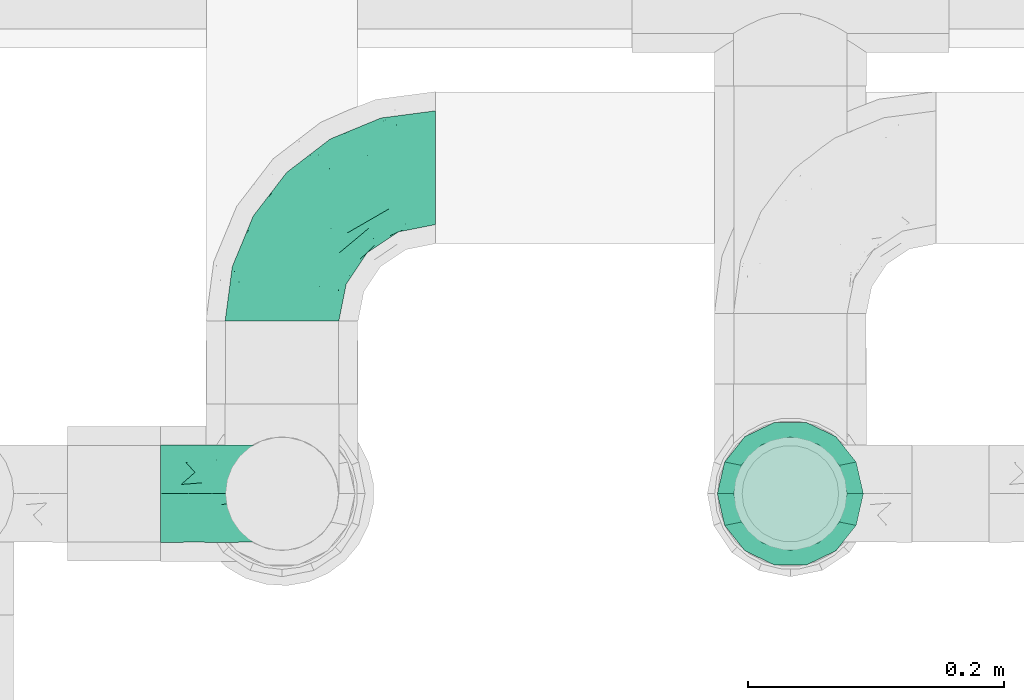
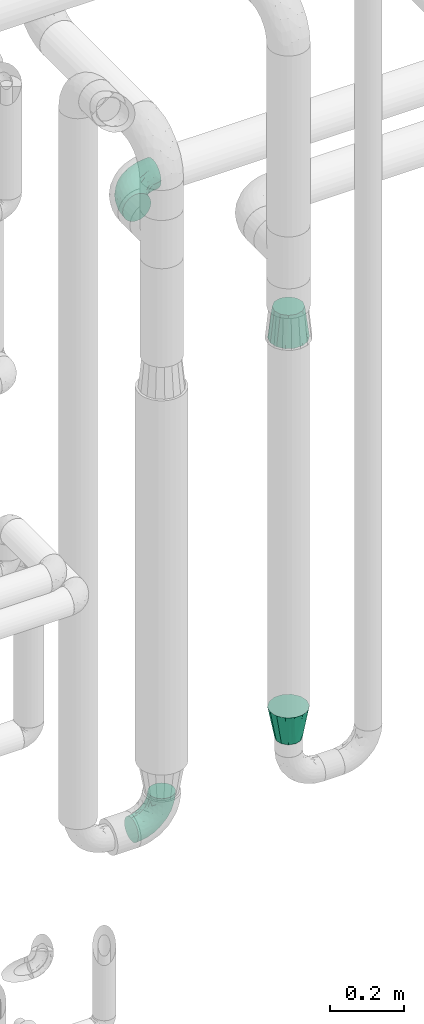
# One storey, part 708 of 827: 4 flow fittings.
"""IFC2X3 building model written with IfcOpenShell, lengths in millimetres."""

import ifcopenshell
import ifcopenshell.guid

model = None  # the IFC model being written
_history = None  # IfcOwnerHistory: only IFC2X3 demands one
_inside = {}  # id of a spatial element -> (the spatial element, [elements in it])
_under = {}  # id of a project, library or spatial element -> (it, [spatial elements below it])
_declared = {}  # id of a project -> (the project, [libraries it declares])
_typed = {}  # id of a type object -> (the type object, [elements of that type])
_made_of = {}  # id of a material, layer set ... -> (it, [elements and type objects made of it])


def new_model(schema):
    """Start an empty IFC model of exactly this schema.

    Asked for "IFC4X3", IfcOpenShell would pick the latest addendum, in which some entities
    have other attributes; the version numbers below select the first issue.
    IFC2X3 requires an IfcOwnerHistory on every rooted entity: one is made here for all.
    """
    global model, _history
    if schema == "IFC4X3":
        model = ifcopenshell.file(schema_version=(4, 3, 0, 0))
    else:
        model = ifcopenshell.file(schema=schema)
    _inside.clear()
    _under.clear()
    _declared.clear()
    _typed.clear()
    _made_of.clear()
    _history = None
    if model.schema == "IFC2X3":
        org = make("IfcOrganization", Name="unknown")
        user = make(
            "IfcPersonAndOrganization",
            ThePerson=make("IfcPerson", FamilyName="unknown"),
            TheOrganization=org,
        )
        app = make(
            "IfcApplication",
            ApplicationDeveloper=org,
            Version="unknown",
            ApplicationFullName="unknown",
            ApplicationIdentifier="unknown",
        )
        _history = make(
            "IfcOwnerHistory",
            OwningUser=user,
            OwningApplication=app,
            ChangeAction="ADDED",
            CreationDate=0,
        )
    return model


def make(cls, **values):
    """One entity of the class cls with the attributes given. An attribute that is None is left unset."""
    return model.create_entity(
        cls, **{name: value for name, value in values.items() if value is not None}
    )


def entity(cls, *values):
    """Any entity or typed value of the class cls, its attributes in the order of the schema. None: left unset."""
    e = model.create_entity(cls)
    for i, value in enumerate(values):
        if value is not None:
            e[i] = value
    return e


def rooted(cls, **values):
    """An entity with a GlobalId (a new one), such as an element, a storey or a relation."""
    return make(cls, GlobalId=ifcopenshell.guid.new(), OwnerHistory=_history, **values)


def si_unit(unit_type, name, prefix=None):
    """IfcSIUnit, for example si_unit("LENGTHUNIT", "METRE", prefix="MILLI")."""
    return make("IfcSIUnit", UnitType=unit_type, Prefix=prefix, Name=name)


def converted_unit(unit_type, name, factor, base, dimensions=None, offset=None):
    """IfcConversionBasedUnit, such as the inch: factor (a typed value) times the base unit."""
    return make(
        "IfcConversionBasedUnit"
        if offset is None
        else "IfcConversionBasedUnitWithOffset",
        ConversionOffset=offset,
        Dimensions=None
        if dimensions is None
        else entity("IfcDimensionalExponents", *dimensions),
        UnitType=unit_type,
        Name=name,
        ConversionFactor=make(
            "IfcMeasureWithUnit", ValueComponent=factor, UnitComponent=base
        ),
    )


def derived_unit(unit_type, elements):
    """IfcDerivedUnit: a product of units, each with its exponent."""
    return make(
        "IfcDerivedUnit",
        Elements=[
            make("IfcDerivedUnitElement", Unit=unit, Exponent=power)
            for unit, power in elements
        ],
        UnitType=unit_type,
    )


def assignment(units):
    """IfcUnitAssignment: the units of a project."""
    return None if units is None else make("IfcUnitAssignment", Units=units)


def point(xyz):
    """IfcCartesianPoint."""
    return None if xyz is None else make("IfcCartesianPoint", Coordinates=xyz)


def direction(xyz):
    """IfcDirection."""
    return None if xyz is None else make("IfcDirection", DirectionRatios=xyz)


def frame(location, z_axis=None, x_axis=None):
    """IfcAxis2Placement3D, a coordinate frame: its origin and axes. An axis left out is left unset."""
    return make(
        "IfcAxis2Placement3D",
        Location=point(location),
        Axis=direction(z_axis),
        RefDirection=direction(x_axis),
    )


def origin():
    """The frame at (0, 0, 0) with its axes left unset."""
    return frame((0.0, 0.0, 0.0))


def place(relative_to, where):
    """IfcLocalPlacement: puts the frame where relative to a parent placement (None: the world)."""
    return make(
        "IfcLocalPlacement", PlacementRelTo=relative_to, RelativePlacement=where
    )


def context(
    kind, dimensions, precision=None, world=None, true_north=None, identifier=None
):
    """IfcGeometricRepresentationContext, for example the 3D "Model" context."""
    return make(
        "IfcGeometricRepresentationContext",
        ContextIdentifier=identifier,
        ContextType=kind,
        CoordinateSpaceDimension=dimensions,
        Precision=precision,
        WorldCoordinateSystem=world,
        TrueNorth=true_north,
    )


def subcontext(parent, identifier, kind, view, scale=None):
    """IfcGeometricRepresentationSubContext, for example "Body" below "Model"."""
    return make(
        "IfcGeometricRepresentationSubContext",
        ContextIdentifier=identifier,
        ContextType=kind,
        ParentContext=parent,
        TargetScale=scale,
        TargetView=view,
    )


def project(units=None, contexts=None):
    """IfcProject with its units and contexts."""
    return rooted(
        "IfcProject",
        Name="project",
        RepresentationContexts=contexts,
        UnitsInContext=assignment(units),
    )


def spatial(cls, under=None, at=None, **own):
    """A site, building, storey or space (cls), placed at a placement, below another one or the project."""
    s = rooted(cls, ObjectPlacement=at, **own)
    if under is not None:
        _under.setdefault(under.id(), (under, []))[1].append(s)
    return s


def faces_of(points, faces, orient=None, outer=None):
    """IfcFace entities. A face is a list of loops; a loop is a list of indices into points, from 0.

    orient and outer hold one flag for each loop. By default every Orientation is true, the
    first loop of a face is its IfcFaceOuterBound and the others are IfcFaceBound.
    """
    made = []
    for i, loops in enumerate(faces):
        bounds = []
        for j, loop in enumerate(loops):
            is_outer = j == 0 if outer is None else outer[i][j]
            bounds.append(
                make(
                    "IfcFaceOuterBound" if is_outer else "IfcFaceBound",
                    Bound=make("IfcPolyLoop", Polygon=[points[k] for k in loop]),
                    Orientation=True if orient is None else orient[i][j],
                )
            )
        made.append(make("IfcFace", Bounds=bounds))
    return made


def faceted_brep(points, faces, orient=None, outer=None, voids=None):
    """IfcFacetedBrep: a solid bounded by flat faces; with voids (closed shells), ...WithVoids."""
    shared = [point(p) for p in points]
    hull = make("IfcClosedShell", CfsFaces=faces_of(shared, faces, orient, outer))
    if voids is None:
        return make("IfcFacetedBrep", Outer=hull)
    return make(
        "IfcFacetedBrepWithVoids",
        Outer=hull,
        Voids=[
            make(cls, CfsFaces=faces_of(shared, fs, o, b)) for cls, fs, o, b in voids
        ],
    )


def shape(context_of_items, identifier, shape_type, items):
    """IfcShapeRepresentation: the items that make up one representation, for example the "Body"."""
    return make(
        "IfcShapeRepresentation",
        ContextOfItems=context_of_items,
        RepresentationIdentifier=identifier,
        RepresentationType=shape_type,
        Items=items,
    )


def source(mapping_origin, context_of_items, identifier, shape_type, items):
    """IfcRepresentationMap: a shape defined once, which mapped items show again and again."""
    return make(
        "IfcRepresentationMap",
        MappingOrigin=mapping_origin,
        MappedRepresentation=shape(context_of_items, identifier, shape_type, items),
    )


def transform(
    local_origin,
    x_axis=None,
    y_axis=None,
    z_axis=None,
    scale=None,
    scale2=None,
    scale3=None,
    uniform=True,
):
    """IfcCartesianTransformationOperator3D, or its non-uniform kind. x_axis, y_axis, z_axis: its Axis1, 2, 3."""
    if uniform:
        return make(
            "IfcCartesianTransformationOperator3D",
            Axis1=direction(x_axis),
            Axis2=direction(y_axis),
            LocalOrigin=point(local_origin),
            Scale=scale,
            Axis3=direction(z_axis),
        )
    return make(
        "IfcCartesianTransformationOperator3DnonUniform",
        Axis1=direction(x_axis),
        Axis2=direction(y_axis),
        LocalOrigin=point(local_origin),
        Scale=scale,
        Axis3=direction(z_axis),
        Scale2=scale2,
        Scale3=scale3,
    )


def mapped(mapping_source, mapping_target):
    """IfcMappedItem: shows the shape of a source again, moved by a transform."""
    return make(
        "IfcMappedItem", MappingSource=mapping_source, MappingTarget=mapping_target
    )


def material(Name=None, Category=None):
    """IfcMaterial."""
    return make("IfcMaterial", Name=Name, Category=Category)


def made_of(thing, what):
    """Note that an element or type object is made of a material, layer set ...; save() writes the relation."""
    if what is not None:
        _made_of.setdefault(what.id(), (what, []))[1].append(thing)
    return thing


def type_object(cls, material=None, **own):
    """A type object (cls), such as IfcWallType, which elements share."""
    return made_of(rooted(cls, **own), material)


def type_shapes(of_type, sources):
    """Give a type object the sources (RepresentationMaps) that its elements show as mapped items."""
    of_type.RepresentationMaps = sources


def element(
    cls,
    number,
    at=None,
    inside=None,
    cuts=None,
    type_object=None,
    material=None,
    context=None,
    identifier="Body",
    shape_type=None,
    held_by="IfcProductDefinitionShape",
    body=None,
    shapes=None,
    **own,
):
    """One element of the class cls, such as IfcWall. Its Tag is "e" and its number.

    at: its placement. inside: the storey or other place that contains it. cuts: it is an
    opening in that element (IfcRelVoidsElement). A single representation is given by context,
    identifier, shape_type and body (its items); several are given by shapes. held_by: the class
    of the entity that holds the representations. save() writes the other relations.
    """
    e = rooted(cls, Tag="e%d" % number, ObjectPlacement=at, **own)
    if body is not None:
        shapes = [shape(context, identifier, shape_type, body)]
    if shapes is not None:
        e.Representation = make(held_by, Representations=shapes)
    if inside is not None:
        _inside.setdefault(inside.id(), (inside, []))[1].append(e)
    if cuts is not None:
        rooted(
            "IfcRelVoidsElement", RelatingBuildingElement=cuts, RelatedOpeningElement=e
        )
    if type_object is not None:
        _typed.setdefault(type_object.id(), (type_object, []))[1].append(e)
    return made_of(e, material)


def aggregate(whole, parts):
    """IfcRelAggregates: a whole, such as a stair, and the parts it consists of."""
    return rooted("IfcRelAggregates", RelatingObject=whole, RelatedObjects=parts)


def save(model, path):
    """Write the relations noted so far, then the file.

    IfcRelAggregates (storeys below a building ...), IfcRelContainedInSpatialStructure (elements
    in a storey), IfcRelDefinesByType, IfcRelAssociatesMaterial and IfcRelDeclares: one each for
    every whole, place, type object, material and project.
    """
    for whole, parts in _under.values():
        aggregate(whole, parts)
    for where, things in _inside.values():
        rooted(
            "IfcRelContainedInSpatialStructure",
            RelatedElements=things,
            RelatingStructure=where,
        )
    for kind, things in _typed.values():
        rooted("IfcRelDefinesByType", RelatedObjects=things, RelatingType=kind)
    for what, things in _made_of.values():
        rooted("IfcRelAssociatesMaterial", RelatedObjects=things, RelatingMaterial=what)
    for by, libraries in _declared.values():
        rooted("IfcRelDeclares", RelatingContext=by, RelatedDefinitions=libraries)
    model.write(path)


model = new_model("IFC2X3")

# Units and contexts
model_context = context("Model", 3, precision=0.01, world=origin(), true_north=direction((6.12303176911189e-17, 1.0)))
body_context = subcontext(model_context, "Body", "Model", "MODEL_VIEW")
ifc_project = project(units=[si_unit("LENGTHUNIT", "METRE", prefix="MILLI"), si_unit("AREAUNIT", "SQUARE_METRE"), si_unit("VOLUMEUNIT", "CUBIC_METRE"), converted_unit("PLANEANGLEUNIT", "DEGREE", entity("IfcRatioMeasure", 0.0174532925199433), si_unit("PLANEANGLEUNIT", "RADIAN"), dimensions=[0, 0, 0, 0, 0, 0, 0]), si_unit("MASSUNIT", "GRAM", prefix="KILO"), derived_unit("MASSDENSITYUNIT", [(si_unit("MASSUNIT", "GRAM", prefix="KILO"), 1), (si_unit("LENGTHUNIT", "METRE"), -3)]), derived_unit("MOMENTOFINERTIAUNIT", [(si_unit("LENGTHUNIT", "METRE"), 4)]), si_unit("TIMEUNIT", "SECOND"), si_unit("FREQUENCYUNIT", "HERTZ"), si_unit("THERMODYNAMICTEMPERATUREUNIT", "DEGREE_CELSIUS"), derived_unit("THERMALTRANSMITTANCEUNIT", [(si_unit("MASSUNIT", "GRAM", prefix="KILO"), 1), (si_unit("THERMODYNAMICTEMPERATUREUNIT", "KELVIN"), -1), (si_unit("TIMEUNIT", "SECOND"), -3)]), derived_unit("VOLUMETRICFLOWRATEUNIT", [(si_unit("LENGTHUNIT", "METRE"), 3), (si_unit("TIMEUNIT", "SECOND"), -1)]), derived_unit("MASSFLOWRATEUNIT", [(si_unit("MASSUNIT", "GRAM", prefix="KILO"), 1), (si_unit("TIMEUNIT", "SECOND"), -1)]), derived_unit("ROTATIONALFREQUENCYUNIT", [(si_unit("TIMEUNIT", "SECOND"), -1)]), si_unit("ELECTRICCURRENTUNIT", "AMPERE"), si_unit("ELECTRICVOLTAGEUNIT", "VOLT"), si_unit("POWERUNIT", "WATT"), si_unit("FORCEUNIT", "NEWTON", prefix="KILO"), si_unit("ILLUMINANCEUNIT", "LUX"), si_unit("LUMINOUSFLUXUNIT", "LUMEN"), si_unit("LUMINOUSINTENSITYUNIT", "CANDELA"), derived_unit("USERDEFINED", [(si_unit("MASSUNIT", "GRAM", prefix="KILO"), -1), (si_unit("LENGTHUNIT", "METRE"), -2), (si_unit("TIMEUNIT", "SECOND"), 3), (si_unit("LUMINOUSFLUXUNIT", "LUMEN"), 1)]), derived_unit("LINEARVELOCITYUNIT", [(si_unit("LENGTHUNIT", "METRE"), 1), (si_unit("TIMEUNIT", "SECOND"), -1)]), si_unit("PRESSUREUNIT", "PASCAL"), derived_unit("USERDEFINED", [(si_unit("LENGTHUNIT", "METRE"), -2), (si_unit("MASSUNIT", "GRAM", prefix="KILO"), 1), (si_unit("TIMEUNIT", "SECOND"), -2)]), derived_unit("LINEARFORCEUNIT", [(si_unit("MASSUNIT", "GRAM", prefix="KILO"), 1), (si_unit("LENGTHUNIT", "METRE"), 1), (si_unit("TIMEUNIT", "SECOND"), -2), (si_unit("LENGTHUNIT", "METRE"), -1)]), derived_unit("PLANARFORCEUNIT", [(si_unit("MASSUNIT", "GRAM", prefix="KILO"), 1), (si_unit("LENGTHUNIT", "METRE"), 1), (si_unit("TIMEUNIT", "SECOND"), -2), (si_unit("LENGTHUNIT", "METRE"), -2)])], contexts=[model_context])

# Site, building, storey
site_placement = place(None, origin())
site = spatial("IfcSite", under=ifc_project, at=site_placement, CompositionType="ELEMENT")
building_placement = place(site_placement, origin())
building = spatial("IfcBuilding", under=site, at=building_placement, CompositionType="ELEMENT")
storey_placement = place(building_placement, frame((0.0, 0.0, 28200.0)))
storey = spatial("IfcBuildingStorey", under=building, at=storey_placement, Name="08", CompositionType="ELEMENT", Elevation=28200.0)

# Flow fittings
ifc_material = material()
pipe_fitting_type_1 = type_object("IfcPipeFittingType", Name="ADSK_2", PredefinedType="NOTDEFINED", material=ifc_material)
shared_shape_1 = source(origin(), body_context, "Body", "Brep", [
    faceted_brep([(-120.0, 22.25, -38.54), (-120.0, 11.52, -42.98), (-120.0, 0.0, -44.5), (-120.0, -11.52, -42.98), (-120.0, -22.25, -38.54), (-120.0, -31.47, -31.47), (-120.0, -38.54, -22.25), (-120.0, -42.98, -11.52), (-120.0, -44.5, 0.0), (-120.0, -42.98, 11.52), (-120.0, -38.54, 22.25), (-120.0, -31.47, 31.47), (-120.0, -22.25, 38.54), (-120.0, -11.52, 42.98), (-120.0, 0.0, 44.5), (-120.0, 11.52, 42.98), (-120.0, 22.25, 38.54), (-120.0, 31.47, 31.47), (-120.0, 38.54, 22.25), (-120.0, 42.98, 11.52), (-120.0, 44.5, 0.0), (-120.0, 42.98, -11.52), (-120.0, 38.54, -22.25), (-120.0, 31.47, -31.47), (0.0, 120.0, -44.5), (-11.52, 120.0, -42.98), (-22.25, 120.0, -38.54), (-31.47, 120.0, -31.47), (-38.54, 120.0, -22.25), (-42.98, 120.0, -11.52), (-44.5, 120.0, 0.0), (-42.98, 120.0, 11.52), (-38.54, 120.0, 22.25), (-31.47, 120.0, 31.47), (-22.25, 120.0, 38.54), (-11.52, 120.0, 42.98), (0.0, 120.0, 44.5), (11.52, 120.0, 42.98), (22.25, 120.0, 38.54), (31.47, 120.0, 31.47), (38.54, 120.0, 22.25), (42.98, 120.0, 11.52), (44.5, 120.0, 0.0), (42.98, 120.0, -11.52), (38.54, 120.0, -22.25), (31.47, 120.0, -31.47), (22.25, 120.0, -38.54), (11.52, 120.0, -42.98), (-20.51, 85.66, 41.98), (-29.31, 93.55, 36.45), (-98.0, -41.6, 0.0), (-80.92, -37.22, 14.68), (-66.68, -9.63, 39.67), (-84.59, -24.55, 33.9), (-50.35, -12.87, 32.85), (-77.42, -38.89, 0.0), (-22.01, -9.62, 13.21), (-37.75, -22.46, 0.0), (-20.72, -9.39, 0.0), (-89.18, -33.47, 25.4), (12.87, 50.35, 32.85), (24.55, 84.59, 33.9), (9.63, 66.68, 39.67), (-49.55, -27.06, 11.21), (-28.67, -9.99, 21.67), (-52.01, -22.41, 23.47), (-95.53, -16.28, 40.49), (-86.01, -3.42, 43.77), (22.41, 52.01, 23.47), (9.05, 21.37, 13.44), (26.5, 49.37, 12.73), (33.47, 89.18, 25.4), (37.22, 80.92, 14.68), (16.28, 95.53, 40.49), (3.42, 86.01, 43.77), (-7.84, 52.6, 43.16), (-84.39, 31.88, 36.84), (-30.52, 34.28, 44.33), (-21.99, 28.55, 42.22), (-93.56, 38.23, 28.63), (-65.04, 31.74, 41.51), (-91.98, 19.0, 41.83), (-34.03, 70.24, 39.41), (-96.36, 44.0, 18.64), (-98.49, 46.74, 8.65), (-76.5, 56.97, 9.76), (-4.96, 4.47, 11.32), (-7.16, 6.18, 18.93), (-56.62, 75.93, 12.18), (-66.61, 66.61, 0.0), (-92.12, 7.25, 44.33), (-7.23, 92.66, 44.32), (30.68, 57.59, 0.0), (-44.45, 94.8, 18.75), (-36.39, 101.98, 28.14), (-46.83, 97.45, 9.69), (-38.03, 47.61, 43.21), (-24.7, 65.7, 43.29), (41.6, 98.0, 0.0), (-54.11, 72.8, 21.53), (-47.95, 9.75, 42.93), (-18.65, 18.65, 37.89), (-91.11, 50.25, 0.0), (-50.25, 91.11, 0.0), (-57.59, -30.68, 0.0), (-44.16, 67.2, 34.92), (-55.15, 62.16, 29.74), (-68.1, 47.21, 32.31), (-51.09, 51.09, 38.36), (-16.69, 62.62, 44.46), (-58.26, 18.84, 44.48), (-71.55, 55.71, 20.49), (-43.13, 80.04, 29.45), (-37.23, 0.88, 36.78), (-18.15, 10.22, 33.09), (5.51, 28.08, 26.74), (-3.68, 3.68, 0.0), (9.39, 20.72, 0.0), (-2.58, 27.98, 33.59), (-2.38, 41.22, 38.93), (-16.09, 4.55, 27.06), (38.89, 77.42, 0.0), (22.46, 37.75, 0.0), (-92.66, 7.23, -44.32), (-22.01, -9.62, -13.21), (-49.81, -26.66, -12.91), (-28.67, -9.99, -21.67), (-62.62, 16.69, -44.46), (-65.04, 31.74, -41.51), (-38.89, 47.26, -43.11), (-56.62, 75.93, -12.18), (-93.56, 38.23, -28.63), (-84.39, 31.88, -36.84), (16.28, 95.53, -40.49), (3.42, 86.01, -43.77), (-98.49, 46.74, -8.65), (-44.45, 94.8, -18.75), (-54.11, 72.8, -21.53), (-76.5, 56.97, -9.76), (24.55, 84.59, -33.9), (9.63, 66.68, -39.67), (-96.36, 44.0, -18.64), (-29.4, 93.16, -36.47), (-91.98, 19.0, -41.83), (-80.92, -37.22, -14.68), (-52.6, 7.84, -43.16), (-86.01, -3.42, -43.77), (-89.18, -33.47, -25.4), (-52.01, -22.41, -23.47), (-50.35, -12.87, -32.85), (-84.59, -24.55, -33.9), (-66.68, -9.63, -39.67), (-95.53, -16.28, -40.49), (-68.1, 47.21, -32.31), (-35.81, 11.1, -40.85), (-19.61, 28.53, -41.59), (-18.65, 18.65, -37.89), (-4.97, 4.47, -11.34), (9.05, 21.37, -13.44), (-34.28, 30.52, -44.33), (-9.75, 47.95, -42.93), (-2.58, 27.98, -33.59), (-18.15, 10.22, -33.09), (-46.83, 97.45, -9.69), (12.87, 50.35, -32.85), (26.8, 49.13, -11.4), (-7.34, 92.03, -44.33), (-21.02, 83.86, -42.03), (-44.6, 66.82, -34.8), (-55.46, 62.18, -29.47), (37.22, 80.92, -14.68), (33.47, 89.18, -25.4), (-34.39, 70.11, -39.28), (-25.04, 64.41, -43.37), (-18.84, 58.26, -44.48), (22.41, 52.01, -23.47), (-36.39, 101.98, -28.14), (-51.09, 51.09, -38.36), (-43.13, 80.04, -29.45), (-71.55, 55.71, -20.49), (-7.15, 6.2, -18.94), (5.51, 28.08, -26.74), (-37.23, 0.88, -36.78), (-2.38, 41.22, -38.93), (-16.09, 4.55, -27.06)], [[[0, 1, 2, 3, 4, 5, 6, 7, 8, 9, 10, 11, 12, 13, 14, 15, 16, 17, 18, 19, 20, 21, 22, 23]], [[24, 25, 26, 27, 28, 29, 30, 31, 32, 33, 34, 35, 36, 37, 38, 39, 40, 41, 42, 43, 44, 45, 46, 47]], [[48, 34, 49]], [[50, 51, 9]], [[52, 53, 54]], [[9, 51, 10]], [[55, 51, 50]], [[56, 57, 58]], [[51, 59, 10]], [[60, 61, 62]], [[63, 64, 65]], [[13, 12, 66]], [[67, 14, 13]], [[68, 69, 70]], [[71, 68, 72]], [[38, 73, 61]], [[74, 75, 62]], [[17, 16, 76]], [[77, 78, 75]], [[79, 18, 17]], [[80, 76, 81]], [[35, 34, 48]], [[49, 82, 48]], [[18, 83, 19]], [[16, 81, 76]], [[20, 19, 84]], [[85, 84, 83]], [[56, 86, 87]], [[85, 88, 89]], [[37, 36, 74]], [[90, 14, 67]], [[79, 17, 76]], [[63, 65, 51]], [[13, 66, 67]], [[61, 39, 38]], [[91, 74, 36]], [[70, 92, 72]], [[93, 94, 32]], [[95, 88, 93]], [[62, 73, 74]], [[82, 96, 97]], [[40, 72, 41]], [[72, 68, 70]], [[71, 72, 40]], [[34, 33, 49]], [[72, 98, 41]], [[99, 93, 88]], [[71, 39, 61]], [[78, 100, 101]], [[85, 89, 102]], [[53, 52, 66]], [[103, 95, 30]], [[12, 11, 53]], [[103, 89, 88]], [[104, 57, 63]], [[91, 48, 97]], [[93, 32, 31]], [[33, 32, 94]], [[16, 15, 81]], [[105, 106, 107]], [[76, 107, 79]], [[35, 91, 36]], [[80, 96, 108]], [[31, 95, 93]], [[65, 53, 59]], [[73, 38, 37]], [[75, 74, 109]], [[61, 60, 68]], [[11, 10, 59]], [[54, 53, 65]], [[100, 67, 52]], [[110, 81, 90]], [[15, 14, 90]], [[76, 80, 108]], [[107, 76, 108]], [[83, 79, 111]], [[94, 49, 33]], [[82, 105, 108]], [[84, 85, 102]], [[111, 88, 85]], [[99, 88, 111]], [[94, 93, 112]], [[48, 91, 35]], [[74, 91, 109]], [[69, 87, 86]], [[113, 54, 114]], [[64, 56, 87]], [[60, 115, 68]], [[116, 117, 86]], [[69, 68, 115]], [[79, 83, 18]], [[85, 83, 111]], [[81, 110, 80]], [[110, 77, 96]], [[110, 96, 80]], [[97, 96, 109]], [[107, 108, 105]], [[111, 79, 107]], [[77, 75, 109]], [[118, 119, 101]], [[96, 77, 109]], [[77, 110, 100]], [[67, 100, 110]], [[100, 52, 113]], [[60, 119, 118]], [[118, 120, 115]], [[64, 54, 65]], [[114, 120, 118]], [[118, 115, 60]], [[115, 120, 87]], [[74, 73, 37]], [[61, 73, 62]], [[53, 66, 12]], [[67, 66, 52]], [[110, 90, 67]], [[15, 90, 81]], [[105, 49, 112]], [[96, 82, 108]], [[119, 60, 62]], [[118, 101, 114]], [[62, 75, 119]], [[78, 119, 75]], [[49, 105, 82]], [[105, 112, 106]], [[99, 112, 93]], [[111, 107, 106]], [[113, 114, 101]], [[54, 120, 114]], [[100, 113, 101]], [[52, 54, 113]], [[20, 84, 102]], [[83, 84, 19]], [[111, 106, 99]], [[112, 99, 106]], [[100, 78, 77]], [[119, 78, 101]], [[39, 71, 40]], [[68, 71, 61]], [[65, 59, 51]], [[11, 59, 53]], [[30, 95, 31]], [[103, 88, 95]], [[9, 8, 50]], [[98, 72, 121]], [[98, 42, 41]], [[49, 94, 112]], [[56, 63, 57]], [[51, 55, 104]], [[92, 121, 72]], [[86, 58, 116]], [[54, 64, 120]], [[115, 87, 69]], [[120, 64, 87]], [[58, 86, 56]], [[86, 117, 69]], [[91, 97, 109]], [[122, 69, 117]], [[82, 97, 48]], [[63, 56, 64]], [[104, 63, 51]], [[69, 122, 70]], [[92, 70, 122]], [[123, 2, 1]], [[124, 125, 126]], [[127, 128, 129]], [[103, 130, 89]], [[23, 131, 132]], [[47, 133, 134]], [[102, 135, 20]], [[130, 136, 137]], [[102, 138, 135]], [[139, 140, 133]], [[22, 21, 141]], [[27, 26, 142]], [[46, 45, 139]], [[0, 143, 1]], [[6, 144, 7]], [[145, 146, 127]], [[144, 50, 7]], [[147, 148, 144]], [[144, 6, 147]], [[149, 150, 151]], [[4, 3, 152]], [[23, 22, 131]], [[132, 131, 153]], [[43, 42, 98]], [[125, 104, 144]], [[154, 155, 156]], [[146, 151, 152]], [[4, 150, 5]], [[123, 146, 2]], [[157, 158, 117]], [[130, 138, 89]], [[29, 28, 136]], [[159, 160, 155]], [[161, 162, 156]], [[89, 138, 102]], [[163, 30, 29]], [[164, 140, 139]], [[163, 136, 130]], [[23, 132, 0]], [[158, 165, 122]], [[25, 24, 166]], [[0, 132, 143]], [[4, 152, 150]], [[142, 26, 167]], [[3, 2, 146]], [[167, 26, 25]], [[133, 47, 46]], [[168, 153, 169]], [[146, 145, 151]], [[149, 126, 148]], [[44, 170, 171]], [[24, 47, 134]], [[170, 44, 43]], [[144, 148, 125]], [[170, 98, 121]], [[168, 142, 172]], [[129, 173, 174]], [[98, 170, 43]], [[147, 5, 150]], [[157, 58, 124]], [[92, 122, 165]], [[134, 166, 24]], [[175, 139, 171]], [[28, 27, 176]], [[29, 136, 163]], [[132, 128, 143]], [[45, 44, 171]], [[164, 139, 175]], [[160, 134, 140]], [[174, 173, 166]], [[141, 131, 22]], [[132, 153, 177]], [[128, 132, 177]], [[123, 143, 127]], [[172, 142, 167]], [[176, 142, 178]], [[130, 179, 138]], [[138, 179, 141]], [[176, 136, 28]], [[130, 137, 179]], [[174, 166, 134]], [[167, 25, 166]], [[143, 123, 1]], [[146, 123, 127]], [[150, 149, 148]], [[157, 124, 180]], [[181, 161, 164]], [[181, 158, 180]], [[124, 126, 180]], [[170, 165, 175]], [[141, 21, 135]], [[131, 141, 179]], [[131, 179, 153]], [[179, 137, 169]], [[129, 128, 177]], [[127, 143, 128]], [[129, 177, 172]], [[129, 174, 159]], [[159, 145, 127]], [[182, 154, 156]], [[129, 159, 127]], [[159, 174, 160]], [[134, 160, 174]], [[140, 164, 183]], [[162, 182, 156]], [[126, 149, 184]], [[181, 164, 175]], [[164, 161, 183]], [[158, 181, 175]], [[184, 162, 161]], [[146, 152, 3]], [[150, 152, 151]], [[139, 133, 46]], [[134, 133, 140]], [[184, 161, 181]], [[161, 156, 183]], [[155, 183, 156]], [[160, 140, 183]], [[184, 149, 162]], [[182, 162, 149]], [[149, 151, 182]], [[154, 151, 145]], [[151, 154, 182]], [[159, 154, 145]], [[159, 155, 154]], [[183, 155, 160]], [[141, 135, 138]], [[20, 135, 21]], [[136, 178, 137]], [[169, 178, 168]], [[172, 167, 173]], [[168, 172, 177]], [[153, 168, 177]], [[142, 168, 178]], [[179, 169, 153]], [[137, 178, 169]], [[5, 147, 6]], [[148, 147, 150]], [[175, 171, 170]], [[45, 171, 139]], [[130, 103, 163]], [[30, 163, 103]], [[50, 144, 55]], [[50, 8, 7]], [[142, 176, 27]], [[136, 176, 178]], [[126, 125, 148]], [[104, 55, 144]], [[170, 121, 92]], [[58, 57, 124]], [[180, 126, 184]], [[181, 180, 184]], [[180, 158, 157]], [[158, 122, 117]], [[58, 157, 116]], [[172, 173, 129]], [[116, 157, 117]], [[166, 173, 167]], [[124, 57, 125]], [[104, 125, 57]], [[175, 165, 158]], [[92, 165, 170]]]),
])
type_shapes(pipe_fitting_type_1, [shared_shape_1])
flow_fitting_1_placement = place(storey_placement, frame((57050.07, 17755.1, 2300.0), z_axis=(0.0, 0.0, 1.0), x_axis=(-1.0, 0.0, 0.0)))
element("IfcFlowFitting", 1, at=flow_fitting_1_placement, inside=storey, type_object=pipe_fitting_type_1, material=ifc_material, Name="ADSK_2", ObjectType="ADSK_2", context=body_context, shape_type="MappedRepresentation", body=[
    mapped(shared_shape_1, transform((0.0, 0.0, 0.0), scale=1.0)),
])
pipe_fitting_type_2 = type_object("IfcPipeFittingType", Name="ADSK_1", PredefinedType="NOTDEFINED", material=ifc_material)
shared_shape_2 = source(origin(), body_context, "Body", "Brep", [
    faceted_brep([(-95.0, 19.02, -32.95), (-95.0, 9.85, -36.75), (-95.0, 0.0, -38.05), (-95.0, -9.85, -36.75), (-95.0, -19.03, -32.95), (-95.0, -26.91, -26.91), (-95.0, -32.95, -19.03), (-95.0, -36.75, -9.85), (-95.0, -38.05, 0.0), (-95.0, -36.75, 9.85), (-95.0, -32.95, 19.02), (-95.0, -26.91, 26.91), (-95.0, -19.03, 32.95), (-95.0, -9.85, 36.75), (-95.0, 0.0, 38.05), (-95.0, 9.85, 36.75), (-95.0, 19.02, 32.95), (-95.0, 26.91, 26.91), (-95.0, 32.95, 19.02), (-95.0, 36.75, 9.85), (-95.0, 38.05, 0.0), (-95.0, 36.75, -9.85), (-95.0, 32.95, -19.03), (-95.0, 26.91, -26.91), (0.0, 95.0, -38.05), (-9.85, 95.0, -36.75), (-19.02, 95.0, -32.95), (-26.91, 95.0, -26.91), (-32.95, 95.0, -19.03), (-36.75, 95.0, -9.85), (-38.05, 95.0, 0.0), (-36.75, 95.0, 9.85), (-32.95, 95.0, 19.02), (-26.91, 95.0, 26.91), (-19.02, 95.0, 32.95), (-9.85, 95.0, 36.75), (0.0, 95.0, 38.05), (9.85, 95.0, 36.75), (19.03, 95.0, 32.95), (26.91, 95.0, 26.91), (32.95, 95.0, 19.02), (36.75, 95.0, 9.85), (38.05, 95.0, 0.0), (36.75, 95.0, -9.85), (32.95, 95.0, -19.03), (26.91, 95.0, -26.91), (19.03, 95.0, -32.95), (9.85, 95.0, -36.75), (-7.99, -4.96, 6.3), (-0.92, 0.92, 0.0), (4.62, 8.1, 8.01), (-76.19, -35.57, 0.0), (-64.32, -32.32, 12.43), (20.51, 62.45, 28.68), (-60.56, -33.52, 0.0), (-70.4, -13.47, 34.42), (-39.61, -5.88, 32.32), (-49.6, 2.07, 37.1), (-70.34, -28.81, 21.71), (14.64, 40.81, 26.5), (5.88, 39.61, 32.32), (3.59, 20.77, 25.31), (-40.45, 68.06, 16.75), (-62.45, -20.51, 28.68), (-44.52, -26.87, 0.0), (-28.47, -20.22, 0.0), (-26.43, -17.83, 8.75), (-76.1, 39.63, 10.76), (-72.74, 37.58, 18.19), (-60.35, 46.18, 14.61), (-13.4, 13.4, 32.12), (-20.77, -3.59, 25.31), (-14.66, 81.47, 35.56), (-6.22, 71.26, 37.92), (-57.5, 42.48, 22.79), (-15.0, 34.74, 37.7), (-27.1, 12.08, 36.05), (-9.2, 28.81, 35.63), (-79.98, 23.7, 30.95), (-73.68, -4.3, 37.48), (-30.74, 21.67, 37.97), (-62.36, 47.59, 6.79), (-72.71, 32.83, 24.69), (-67.42, 7.02, 37.95), (-32.13, 75.27, 24.51), (-43.46, 51.47, 26.26), (-24.98, 73.15, 31.29), (20.59, 41.28, 19.85), (7.79, 16.09, 15.86), (-73.21, 42.39, 0.0), (-54.73, 54.73, 0.0), (-73.44, 15.79, 35.79), (-5.94, 4.32, 20.43), (28.81, 70.34, 21.71), (32.32, 64.32, 12.43), (-53.59, 26.2, 35.09), (-52.02, 19.31, 37.21), (21.38, 33.53, 10.34), (26.87, 44.52, 0.0), (-48.28, 12.14, 38.05), (4.3, 73.68, 37.48), (-44.08, -25.52, 12.79), (-41.28, -20.59, 19.85), (35.57, 76.19, 0.0), (-47.26, 54.3, 20.18), (-47.4, 61.99, 8.58), (-42.39, 73.21, 0.0), (-39.67, 78.86, 7.21), (-45.69, 36.84, 33.11), (-32.83, 50.13, 33.35), (13.47, 70.4, 34.42), (-18.25, 63.73, 36.07), (-40.63, -13.75, 27.22), (-16.63, 46.37, 37.95), (-53.47, 38.79, 28.59), (-26.07, 48.54, 36.15), (-34.51, 34.51, 36.86), (-2.07, 49.6, 37.1), (-22.79, -10.49, 19.23), (-61.73, 28.67, 31.87), (9.65, 14.7, 0.0), (20.22, 28.47, 0.0), (33.52, 60.56, 0.0), (-11.42, -5.44, 13.25), (-14.7, -9.65, 0.0), (-81.47, 14.66, -35.56), (-62.45, -20.51, -28.68), (-71.26, 6.22, -37.92), (-75.27, 32.13, -24.51), (-73.15, 24.98, -31.29), (13.47, 70.4, -34.42), (5.88, 39.61, -32.32), (-2.07, 49.6, -37.1), (-78.86, 39.67, -7.21), (-70.4, -13.47, -34.42), (-39.61, -5.88, -32.32), (-61.99, 47.4, -8.58), (32.32, 64.32, -12.43), (28.81, 70.34, -21.71), (-63.73, 18.25, -36.07), (-50.13, 32.83, -33.35), (4.3, 73.68, -37.48), (-7.02, 67.42, -37.95), (-39.63, 76.1, -10.76), (-46.18, 60.35, -14.61), (-47.59, 62.36, -6.79), (-64.32, -32.32, -12.43), (-26.2, 53.59, -35.09), (-15.79, 73.44, -35.79), (-19.31, 52.02, -37.21), (-37.58, 72.74, -18.19), (-70.34, -28.81, -21.71), (-42.48, 57.5, -22.79), (-38.79, 53.47, -28.59), (-51.47, 43.46, -26.26), (-32.83, 72.71, -24.69), (-46.37, 16.63, -37.95), (-73.68, -4.3, -37.48), (-41.28, -20.59, -19.85), (-44.08, -25.52, -12.79), (13.75, 40.63, -27.22), (20.51, 62.45, -28.68), (-68.06, 40.45, -16.75), (-54.3, 47.26, -20.18), (-12.14, 48.28, -38.05), (-21.67, 30.74, -37.97), (-36.84, 45.69, -33.11), (-11.42, -5.44, -13.25), (7.79, 16.09, -15.86), (4.62, 8.1, -8.01), (-23.7, 79.98, -30.95), (-26.43, -17.83, -8.75), (-7.99, -4.96, -6.3), (-40.81, -14.64, -26.5), (-20.77, -3.59, -25.31), (-34.74, 15.0, -37.7), (-12.08, 27.1, -36.05), (-28.81, 9.2, -35.63), (-22.79, -10.49, -19.23), (21.38, 33.53, -10.34), (20.59, 41.28, -19.85), (-48.54, 26.07, -36.15), (-49.6, 2.07, -37.1), (-13.4, 13.4, -32.12), (3.59, 20.77, -25.31), (-28.67, 61.73, -31.87), (-34.51, 34.51, -36.86), (-5.94, 4.32, -20.43)], [[[0, 1, 2, 3, 4, 5, 6, 7, 8, 9, 10, 11, 12, 13, 14, 15, 16, 17, 18, 19, 20, 21, 22, 23]], [[24, 25, 26, 27, 28, 29, 30, 31, 32, 33, 34, 35, 36, 37, 38, 39, 40, 41, 42, 43, 44, 45, 46, 47]], [[48, 49, 50]], [[51, 52, 9]], [[53, 39, 38]], [[9, 52, 10]], [[54, 52, 51]], [[55, 56, 57]], [[11, 10, 58]], [[59, 60, 61]], [[32, 31, 62]], [[63, 12, 11]], [[63, 55, 12]], [[64, 65, 66]], [[67, 68, 69]], [[70, 56, 71]], [[35, 72, 73]], [[69, 68, 74]], [[75, 76, 77]], [[16, 78, 17]], [[13, 79, 14]], [[76, 75, 80]], [[67, 69, 81]], [[18, 17, 82]], [[14, 79, 83]], [[20, 19, 67]], [[84, 85, 86]], [[87, 61, 88]], [[89, 81, 90]], [[18, 82, 68]], [[15, 91, 16]], [[14, 83, 15]], [[71, 92, 61]], [[17, 78, 82]], [[93, 87, 94]], [[95, 91, 96]], [[97, 98, 94]], [[86, 72, 34]], [[96, 99, 80]], [[37, 36, 100]], [[40, 39, 93]], [[40, 94, 41]], [[64, 66, 101]], [[93, 94, 40]], [[58, 102, 63]], [[94, 103, 41]], [[94, 87, 97]], [[104, 69, 74]], [[34, 33, 86]], [[105, 69, 104]], [[52, 58, 10]], [[106, 107, 30]], [[108, 109, 85]], [[105, 106, 90]], [[53, 110, 60]], [[86, 111, 72]], [[86, 109, 111]], [[33, 84, 86]], [[12, 55, 13]], [[112, 56, 63]], [[110, 38, 37]], [[34, 72, 35]], [[36, 35, 73]], [[111, 113, 73]], [[105, 107, 106]], [[110, 53, 38]], [[74, 114, 85]], [[91, 15, 83]], [[105, 90, 81]], [[107, 62, 31]], [[33, 32, 84]], [[115, 109, 116]], [[111, 115, 113]], [[100, 73, 117]], [[56, 55, 63]], [[79, 55, 57]], [[102, 118, 112]], [[56, 70, 76]], [[100, 110, 37]], [[117, 77, 60]], [[117, 60, 110]], [[60, 70, 61]], [[58, 52, 101]], [[63, 11, 58]], [[39, 53, 93]], [[87, 93, 53]], [[96, 91, 83]], [[78, 91, 119]], [[32, 62, 84]], [[84, 62, 104]], [[86, 85, 109]], [[85, 114, 108]], [[80, 113, 116]], [[117, 73, 113]], [[80, 116, 96]], [[80, 57, 76]], [[71, 112, 118]], [[61, 87, 59]], [[62, 107, 105]], [[97, 120, 121]], [[70, 71, 61]], [[71, 118, 92]], [[73, 100, 36]], [[110, 100, 117]], [[55, 79, 13]], [[83, 79, 57]], [[96, 83, 99]], [[116, 108, 95]], [[50, 97, 88]], [[97, 87, 88]], [[50, 49, 120]], [[122, 94, 98]], [[89, 20, 67]], [[105, 81, 69]], [[89, 67, 81]], [[68, 19, 18]], [[68, 67, 19]], [[74, 68, 82]], [[114, 82, 119]], [[74, 85, 104]], [[82, 114, 74]], [[114, 119, 108]], [[95, 108, 119]], [[116, 109, 108]], [[123, 48, 50]], [[97, 50, 120]], [[123, 50, 88]], [[91, 95, 119]], [[116, 95, 96]], [[84, 104, 85]], [[104, 62, 105]], [[83, 57, 99]], [[57, 80, 99]], [[66, 48, 123]], [[66, 124, 48]], [[118, 66, 123]], [[124, 66, 65]], [[66, 118, 101]], [[54, 64, 52]], [[124, 49, 48]], [[30, 107, 31]], [[91, 78, 16]], [[82, 78, 119]], [[56, 76, 57]], [[77, 76, 70]], [[60, 77, 70]], [[77, 117, 75]], [[117, 113, 75]], [[113, 80, 75]], [[9, 8, 51]], [[103, 94, 122]], [[103, 42, 41]], [[73, 72, 111]], [[113, 115, 116]], [[111, 109, 115]], [[102, 112, 63]], [[71, 56, 112]], [[118, 102, 101]], [[92, 123, 88]], [[123, 92, 118]], [[61, 92, 88]], [[87, 53, 59]], [[60, 59, 53]], [[97, 121, 98]], [[58, 101, 102]], [[64, 101, 52]], [[125, 1, 0]], [[126, 5, 4]], [[2, 1, 127]], [[1, 125, 127]], [[128, 129, 23]], [[130, 131, 132]], [[89, 133, 20]], [[126, 134, 135]], [[136, 89, 90]], [[137, 138, 44]], [[139, 129, 140]], [[24, 141, 142]], [[143, 144, 145]], [[125, 129, 139]], [[6, 146, 7]], [[147, 148, 149]], [[146, 51, 7]], [[143, 150, 144]], [[146, 6, 151]], [[152, 153, 154]], [[126, 4, 134]], [[0, 23, 129]], [[28, 155, 150]], [[43, 42, 103]], [[54, 146, 64]], [[139, 156, 127]], [[157, 3, 2]], [[151, 158, 159]], [[160, 131, 161]], [[22, 21, 162]], [[136, 144, 163]], [[149, 164, 165]], [[24, 142, 25]], [[166, 140, 154]], [[154, 129, 128]], [[143, 30, 29]], [[167, 168, 169]], [[155, 28, 27]], [[26, 170, 27]], [[171, 167, 172]], [[26, 25, 148]], [[27, 170, 155]], [[173, 135, 174]], [[144, 150, 152]], [[175, 176, 177]], [[24, 47, 141]], [[45, 161, 46]], [[148, 25, 142]], [[176, 175, 165]], [[64, 159, 171]], [[138, 45, 44]], [[130, 46, 161]], [[137, 44, 43]], [[178, 159, 158]], [[137, 103, 122]], [[163, 144, 152]], [[136, 133, 89]], [[103, 137, 43]], [[6, 5, 151]], [[178, 158, 173]], [[134, 4, 3]], [[178, 173, 174]], [[137, 98, 179]], [[145, 90, 106]], [[138, 180, 161]], [[46, 130, 47]], [[136, 90, 145]], [[133, 162, 21]], [[23, 22, 128]], [[139, 140, 181]], [[139, 181, 156]], [[157, 127, 182]], [[157, 134, 3]], [[182, 177, 135]], [[182, 135, 134]], [[135, 183, 174]], [[131, 130, 161]], [[141, 130, 132]], [[160, 180, 184]], [[131, 183, 176]], [[5, 126, 151]], [[158, 151, 126]], [[180, 138, 137]], [[161, 45, 138]], [[149, 148, 142]], [[170, 148, 185]], [[22, 162, 128]], [[128, 162, 163]], [[129, 154, 140]], [[154, 153, 166]], [[165, 156, 186]], [[182, 127, 156]], [[165, 186, 149]], [[165, 132, 176]], [[131, 184, 183]], [[187, 167, 178]], [[184, 168, 187]], [[167, 169, 172]], [[184, 180, 168]], [[174, 183, 184]], [[127, 157, 2]], [[134, 157, 182]], [[130, 141, 47]], [[142, 141, 132]], [[149, 142, 164]], [[186, 166, 147]], [[180, 179, 168]], [[169, 179, 120]], [[137, 179, 180]], [[179, 121, 120]], [[106, 30, 143]], [[136, 145, 144]], [[106, 143, 145]], [[150, 29, 28]], [[150, 143, 29]], [[152, 150, 155]], [[153, 155, 185]], [[152, 154, 163]], [[155, 153, 152]], [[153, 185, 166]], [[147, 166, 185]], [[186, 140, 166]], [[169, 120, 49]], [[169, 49, 172]], [[179, 169, 168]], [[148, 147, 185]], [[186, 147, 149]], [[128, 163, 154]], [[163, 162, 136]], [[142, 132, 164]], [[132, 165, 164]], [[171, 124, 65]], [[124, 171, 172]], [[64, 146, 159]], [[171, 159, 178]], [[171, 65, 64]], [[172, 49, 124]], [[162, 133, 136]], [[20, 133, 21]], [[148, 170, 26]], [[155, 170, 185]], [[131, 176, 132]], [[177, 176, 183]], [[135, 177, 183]], [[177, 182, 175]], [[182, 156, 175]], [[156, 165, 175]], [[51, 146, 54]], [[51, 8, 7]], [[129, 125, 0]], [[127, 125, 139]], [[140, 186, 181]], [[156, 181, 186]], [[158, 126, 173]], [[135, 173, 126]], [[187, 178, 174]], [[171, 178, 167]], [[184, 187, 174]], [[167, 187, 168]], [[180, 160, 161]], [[184, 131, 160]], [[98, 137, 122]], [[98, 121, 179]], [[151, 159, 146]]]),
])
type_shapes(pipe_fitting_type_2, [shared_shape_2])
flow_fitting_2_placement = place(storey_placement, frame((57050.07, 17500.0, 352.5), z_axis=(0.0, -1.0, 0.0), x_axis=(1.0, 0.0, 0.0)))
element("IfcFlowFitting", 2, at=flow_fitting_2_placement, inside=storey, type_object=pipe_fitting_type_2, material=ifc_material, Name="ADSK_1", ObjectType="ADSK_1", context=body_context, shape_type="MappedRepresentation", body=[
    mapped(shared_shape_2, transform((0.0, 0.0, 0.0), scale=1.0)),
])
pipe_fitting_type_3 = type_object("IfcPipeFittingType", Name="ADSK_1", PredefinedType="NOTDEFINED", material=ifc_material)
shared_shape_3 = source(origin(), body_context, "Body", "Brep", [
    faceted_brep([(102.0, -57.15, 0.0), (102.0, -54.32, -12.4), (102.0, -51.49, -24.8), (102.0, -43.56, -34.74), (102.0, -35.63, -44.68), (102.0, -24.17, -50.2), (102.0, -12.72, -55.72), (102.0, 0.0, -55.72), (102.0, 12.72, -55.72), (102.0, 24.17, -50.2), (102.0, 35.63, -44.68), (102.0, 43.56, -34.74), (102.0, 51.49, -24.8), (102.0, 54.32, -12.4), (102.0, 57.15, 0.0), (102.0, 54.32, 12.4), (102.0, 51.49, 24.8), (102.0, 43.56, 34.74), (102.0, 35.63, 44.68), (102.0, 24.17, 50.2), (102.0, 12.72, 55.72), (102.0, 0.0, 55.72), (102.0, -12.72, 55.72), (102.0, -24.17, 50.2), (102.0, -35.63, 44.68), (102.0, -43.56, 34.74), (102.0, -51.49, 24.8), (102.0, -54.32, 12.4), (0.0, -38.49, -22.22), (0.0, -41.47, -11.11), (0.0, -44.45, 0.0), (0.0, -41.47, 11.11), (0.0, -38.49, 22.23), (0.0, -30.36, 30.36), (0.0, -22.23, 38.49), (0.0, -11.11, 41.47), (0.0, 0.0, 44.45), (0.0, 11.11, 41.47), (0.0, 22.23, 38.49), (0.0, 30.36, 30.36), (0.0, 38.49, 22.23), (0.0, 41.47, 11.11), (0.0, 44.45, 0.0), (0.0, 41.47, -11.11), (0.0, 38.49, -22.23), (0.0, 30.36, -30.36), (0.0, 22.22, -38.49), (0.0, 11.11, -41.47), (0.0, 0.0, -44.45), (0.0, -11.11, -41.47), (0.0, -22.23, -38.49), (0.0, -30.36, -30.36)], [[[0, 1, 2, 3, 4, 5, 6, 7, 8, 9, 10, 11, 12, 13, 14, 15, 16, 17, 18, 19, 20, 21, 22, 23, 24, 25, 26, 27]], [[28, 29, 30, 31, 32, 33, 34, 35, 36, 37, 38, 39, 40, 41, 42, 43, 44, 45, 46, 47, 48, 49, 50, 51]], [[28, 2, 29]], [[11, 10, 45]], [[11, 44, 12]], [[3, 2, 28]], [[30, 29, 1]], [[42, 13, 43]], [[30, 1, 0]], [[46, 10, 9]], [[48, 8, 7, 6]], [[28, 51, 3]], [[29, 2, 1]], [[47, 46, 9]], [[5, 4, 50]], [[51, 4, 3]], [[8, 48, 47]], [[13, 42, 14]], [[51, 50, 4]], [[8, 47, 9]], [[5, 49, 6]], [[44, 11, 45]], [[43, 12, 44]], [[10, 46, 45]], [[49, 5, 50]], [[49, 48, 6]], [[13, 12, 43]], [[40, 16, 41]], [[25, 24, 33]], [[25, 32, 26]], [[17, 16, 40]], [[42, 41, 15]], [[30, 27, 31]], [[42, 15, 14]], [[34, 24, 23]], [[36, 22, 21, 20]], [[40, 39, 17]], [[41, 16, 15]], [[35, 34, 23]], [[19, 18, 38]], [[39, 18, 17]], [[22, 36, 35]], [[27, 30, 0]], [[39, 38, 18]], [[22, 35, 23]], [[19, 37, 20]], [[32, 25, 33]], [[31, 26, 32]], [[24, 34, 33]], [[37, 19, 38]], [[37, 36, 20]], [[27, 26, 31]]]),
])
type_shapes(pipe_fitting_type_3, [shared_shape_3])
flow_fitting_3_placement = place(storey_placement, frame((57447.89, 17500.0, 1915.45), z_axis=(0.0, 1.0, 0.0), x_axis=(0.0, 0.0, -1.0)))
element("IfcFlowFitting", 3, at=flow_fitting_3_placement, inside=storey, type_object=pipe_fitting_type_3, material=ifc_material, Name="ADSK_1", ObjectType="ADSK_1", context=body_context, shape_type="MappedRepresentation", body=[
    mapped(shared_shape_3, transform((0.0, 0.0, 0.0), scale=1.0)),
])
pipe_fitting_type_4 = type_object("IfcPipeFittingType", Name="ADSK_1", PredefinedType="NOTDEFINED", material=ifc_material)
shared_shape_4 = source(origin(), body_context, "Body", "Brep", [
    faceted_brep([(102.0, 38.05, 0.0), (102.0, 35.5, 9.51), (102.0, 32.95, 19.03), (102.0, 25.99, 25.99), (102.0, 19.02, 32.95), (102.0, 9.51, 35.5), (102.0, 0.0, 38.05), (102.0, -9.51, 35.5), (102.0, -19.03, 32.95), (102.0, -25.99, 25.99), (102.0, -32.95, 19.03), (102.0, -35.5, 9.51), (102.0, -38.05, 0.0), (102.0, -35.5, -9.51), (102.0, -32.95, -19.02), (102.0, -25.99, -25.99), (102.0, -19.03, -32.95), (102.0, -9.51, -35.5), (102.0, 0.0, -38.05), (102.0, 9.51, -35.5), (102.0, 19.02, -32.95), (102.0, 25.99, -25.99), (102.0, 32.95, -19.02), (102.0, 35.5, -9.51), (0.0, 43.56, 34.74), (0.0, 51.49, 24.8), (0.0, 54.32, 12.4), (0.0, 57.15, 0.0), (0.0, 54.32, -12.4), (0.0, 51.49, -24.8), (0.0, 43.56, -34.74), (0.0, 35.63, -44.68), (0.0, 24.17, -50.2), (0.0, 12.72, -55.72), (0.0, 0.0, -55.72), (0.0, -12.72, -55.72), (0.0, -24.17, -50.2), (0.0, -35.63, -44.68), (0.0, -43.56, -34.74), (0.0, -51.49, -24.8), (0.0, -54.32, -12.4), (0.0, -57.15, 0.0), (0.0, -54.32, 12.4), (0.0, -51.49, 24.8), (0.0, -43.56, 34.74), (0.0, -35.63, 44.68), (0.0, -24.17, 50.2), (0.0, -12.72, 55.72), (0.0, 0.0, 55.72), (0.0, 12.72, 55.72), (0.0, 24.17, 50.2), (0.0, 35.63, 44.68)], [[[0, 1, 2, 3, 4, 5, 6, 7, 8, 9, 10, 11, 12, 13, 14, 15, 16, 17, 18, 19, 20, 21, 22, 23]], [[24, 25, 26, 27, 28, 29, 30, 31, 32, 33, 34, 35, 36, 37, 38, 39, 40, 41, 42, 43, 44, 45, 46, 47, 48, 49, 50, 51]], [[32, 31, 20]], [[40, 12, 41]], [[30, 29, 22]], [[22, 29, 23]], [[40, 39, 13]], [[12, 40, 13]], [[37, 16, 15]], [[18, 35, 34, 33]], [[16, 37, 36]], [[32, 19, 33]], [[36, 17, 16]], [[22, 21, 30]], [[38, 14, 39]], [[23, 29, 28]], [[21, 31, 30]], [[0, 28, 27]], [[36, 35, 17]], [[0, 23, 28]], [[39, 14, 13]], [[14, 38, 15]], [[21, 20, 31]], [[19, 18, 33]], [[35, 18, 17]], [[38, 37, 15]], [[19, 32, 20]], [[46, 45, 8]], [[26, 0, 27]], [[44, 43, 10]], [[10, 43, 11]], [[26, 25, 1]], [[0, 26, 1]], [[51, 4, 3]], [[6, 49, 48, 47]], [[4, 51, 50]], [[46, 7, 47]], [[50, 5, 4]], [[10, 9, 44]], [[24, 2, 25]], [[11, 43, 42]], [[9, 45, 44]], [[12, 42, 41]], [[50, 49, 5]], [[12, 11, 42]], [[25, 2, 1]], [[2, 24, 3]], [[9, 8, 45]], [[7, 6, 47]], [[49, 6, 5]], [[24, 51, 3]], [[7, 46, 8]]]),
])
type_shapes(pipe_fitting_type_4, [shared_shape_4])
flow_fitting_4_placement = place(storey_placement, frame((57447.89, 17500.0, 589.0), z_axis=(0.0, 1.0, 0.0), x_axis=(0.0, 0.0, -1.0)))
element("IfcFlowFitting", 4, at=flow_fitting_4_placement, inside=storey, type_object=pipe_fitting_type_4, material=ifc_material, Name="ADSK_1", ObjectType="ADSK_1", context=body_context, shape_type="MappedRepresentation", body=[
    mapped(shared_shape_4, transform((0.0, 0.0, 0.0), scale=1.0)),
])

save(model, "model.ifc")
